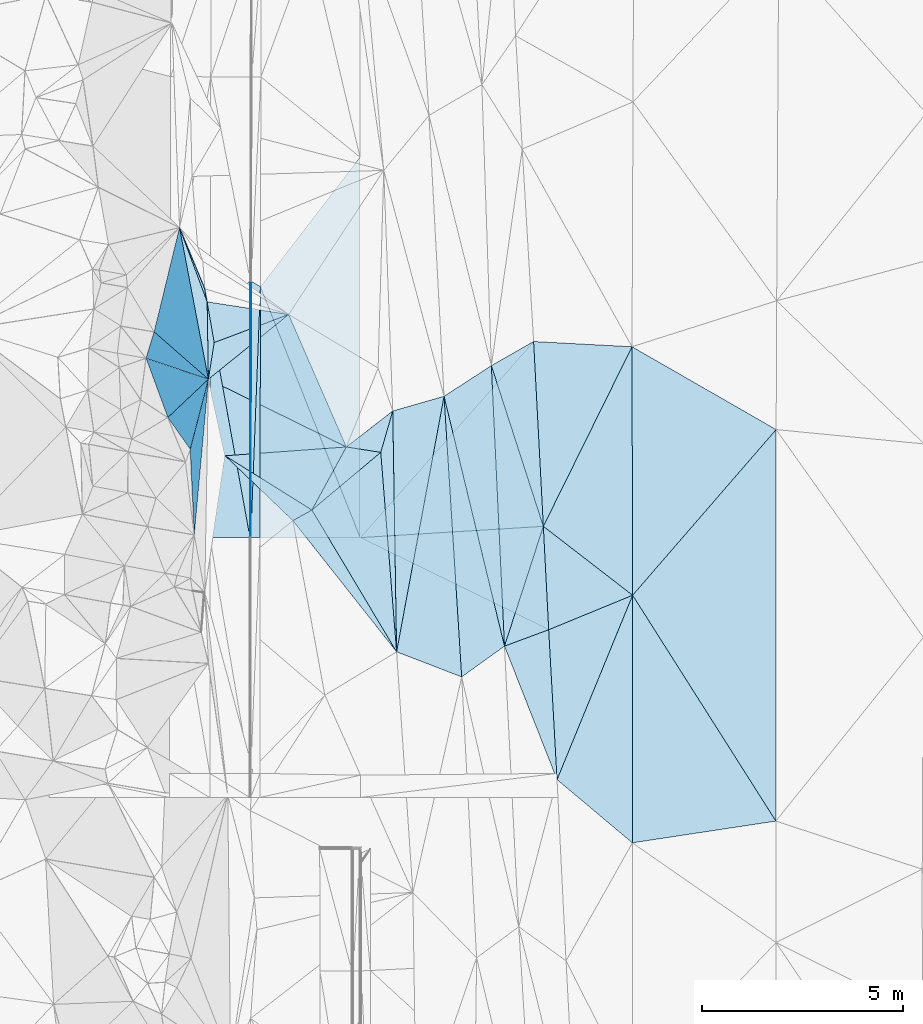
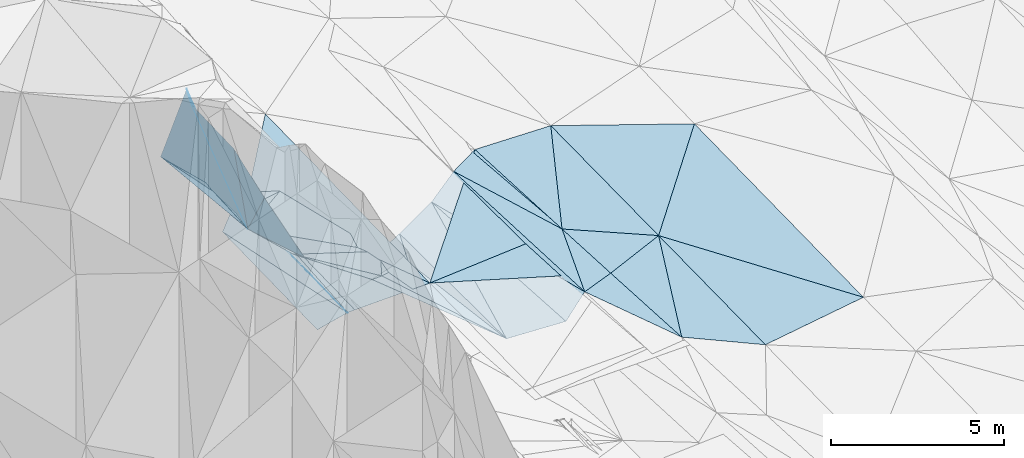
# One storey, part 89 of 275: 45 plates.
"""IFC2X3 building model written with IfcOpenShell, lengths in millimetres."""

from ifc_helpers import new_model, si_unit, frame, origin_with_axes, place, context, subcontext, project, spatial, polyline, outline, extrude, material, type_object, element, save


model = new_model("IFC2X3")

# Units and contexts
model_context = context("Model", 3, precision=1e-05, world=origin_with_axes())
body_context = subcontext(model_context, "Body", "Model", "MODEL_VIEW")
ifc_project = project(units=[si_unit("LENGTHUNIT", "METRE", prefix="MILLI"), si_unit("AREAUNIT", "SQUARE_METRE"), si_unit("VOLUMEUNIT", "CUBIC_METRE"), si_unit("MASSUNIT", "GRAM", prefix="KILO"), si_unit("TIMEUNIT", "SECOND"), si_unit("PLANEANGLEUNIT", "RADIAN"), si_unit("SOLIDANGLEUNIT", "STERADIAN"), si_unit("THERMODYNAMICTEMPERATUREUNIT", "DEGREE_CELSIUS"), si_unit("LUMINOUSINTENSITYUNIT", "LUMEN")], contexts=[model_context])

# Site, building, storey
site_placement = place(None, origin_with_axes())
site = spatial("IfcSite", under=ifc_project, at=site_placement, CompositionType="ELEMENT")
building_placement = place(site_placement, origin_with_axes())
building = spatial("IfcBuilding", under=site, at=building_placement, Name="Undefined", CompositionType="ELEMENT")
storey_placement = place(building_placement, origin_with_axes())
storey = spatial("IfcBuildingStorey", under=building, at=storey_placement, Name="Undefined", CompositionType="ELEMENT", Elevation=0.0)

# Plates
ifc_material = material()
plate_type_1 = type_object("IfcPlateType", PredefinedType="NOTDEFINED")
plate_1_placement = place(storey_placement, frame((-96883.7996210182, 94915.8950093712, 42813.0537546332), z_axis=(0.0502459376288875, 0.0222813070516805, -0.998488301938417), x_axis=(0.857254930137281, -0.513917260983165, 0.0316707060054871)))
element("IfcPlate", 1, at=plate_1_placement, inside=storey, type_object=plate_type_1, material=ifc_material, Name="00_PR", context=body_context, shape_type="SweptSolid", body=[
    extrude(outline(polyline([(0.0, 0.0), (23.3022899627686, 1.67347025126219e-10), (3277.58178710938, 5501.44140625), (0.0, 0.0)])), frame((-8.85201319254618e-08, 2.18876761149539e-07, -0.5000001331573), z_axis=(0.0, 0.0, 1.0), x_axis=(1.0, 0.0, 0.0)), (0.0, 0.0, 1.0), 1.0),
])
plate_2_placement = place(storey_placement, frame((-96863.823764153, 94903.9195599559, 42813.7917470649), z_axis=(0.0499448589059185, 0.022283031205327, -0.998503368842174), x_axis=(-0.00146779893247274, -0.999748364158116, -0.022384233948566)))
element("IfcPlate", 2, at=plate_2_placement, inside=storey, type_object=plate_type_1, material=ifc_material, Name="00_PR", context=body_context, shape_type="SweptSolid", body=[
    extrude(outline(polyline([(0.0, 0.0), (6391.8203125, -1.23254721984267e-08), (6391.853515625, 20.0253582000732), (0.0, 0.0)])), frame((-8.85201319254618e-08, 2.18876761149539e-07, -0.5000001331573), z_axis=(0.0, 0.0, 1.0), x_axis=(1.0, 0.0, 0.0)), (0.0, 0.0, 1.0), 1.0),
])
plate_type_2 = type_object("IfcPlateType", PredefinedType="NOTDEFINED")
plate_3_placement = place(storey_placement, frame((-89242.8984460067, 82484.8215259567, 42789.5002350051), z_axis=(0.0262603371728198, 0.0175187829341471, -0.999501619276365), x_axis=(-0.0555772006600647, 0.998325577359942, 0.0160379660720577)))
element("IfcPlate", 3, at=plate_3_placement, inside=storey, type_object=plate_type_2, material=ifc_material, Name="00", context=body_context, shape_type="SweptSolid", body=[
    extrude(outline(polyline([(0.0, 0.0), (3741.12280273438, 1.12049747258425e-09), (4483.5205078125, 2136.57348632813), (0.0, 0.0)])), frame((-8.85201319254618e-08, 2.18876761149539e-07, -0.5000001331573), z_axis=(0.0, 0.0, 1.0), x_axis=(1.0, 0.0, 0.0)), (0.0, 0.0, 1.0), 1.0),
])
plate_type_3 = type_object("IfcPlateType", PredefinedType="NOTDEFINED")
plate_4_placement = place(storey_placement, frame((-89583.8489318064, 88795.8791784817, 42889.5002332215), z_axis=(0.0265193549940949, 0.016888476092627, -0.999505629391834), x_axis=(0.791501493421083, -0.611073992532343, 0.0106752781124141)))
element("IfcPlate", 4, at=plate_4_placement, inside=storey, type_object=plate_type_3, material=ifc_material, Name="00", context=body_context, shape_type="SweptSolid", body=[
    extrude(outline(polyline([(0.0, 0.0), (2810.23120117188, 3.16504156216979e-09), (1679.11450195313, 1958.7431640625), (0.0, 0.0)])), frame((-8.85201319254618e-08, 2.18876761149539e-07, -0.5000001331573), z_axis=(0.0, 0.0, 1.0), x_axis=(1.0, 0.0, 0.0)), (0.0, 0.0, 1.0), 1.0),
])
plate_type_4 = type_object("IfcPlateType", PredefinedType="NOTDEFINED")
plate_5_placement = place(storey_placement, frame((-96634.0970342402, 94766.1046263451, 42822.2697535346), z_axis=(0.0502163620652991, 0.0222823277283463, -0.998489767024146), x_axis=(-0.0382035539413165, -0.99897654863145, -0.0242145359371038)))
element("IfcPlate", 5, at=plate_5_placement, inside=storey, type_object=plate_type_4, material=ifc_material, Name="00_PR", context=body_context, shape_type="SweptSolid", body=[
    extrude(outline(polyline([(0.0, 0.0), (6258.802734375, -3.84170562028885e-08), (-128.692230224609, 235.111572265625), (0.0, 0.0)])), frame((-8.85201319254618e-08, 2.18876761149539e-07, -0.5000001331573), z_axis=(0.0, 0.0, 1.0), x_axis=(1.0, 0.0, 0.0)), (0.0, 0.0, 1.0), 1.0),
])
plate_6_placement = place(storey_placement, frame((-96873.2056711443, 88513.7077095046, 42670.7157472172), z_axis=(0.049946162670482, 0.022292983617612, -0.998503081475425), x_axis=(0.0382035539401981, 0.99897654863142, 0.0242145359401193)))
element("IfcPlate", 6, at=plate_6_placement, inside=storey, type_object=plate_type_4, material=ifc_material, Name="00_PR", context=body_context, shape_type="SweptSolid", body=[
    extrude(outline(polyline([(0.0, 0.0), (6258.802734375, -3.84170562028885e-08), (8.84989261627197, 230.116790771484), (0.0, 0.0)])), frame((-8.85201319254618e-08, 2.18876761149539e-07, -0.5000001331573), z_axis=(0.0, 0.0, 1.0), x_axis=(1.0, 0.0, 0.0)), (0.0, 0.0, 1.0), 1.0),
])
plate_type_5 = type_object("IfcPlateType", PredefinedType="NOTDEFINED")
plate_7_placement = place(storey_placement, frame((-97885.4751121999, 93996.4223501791, 42542.8029896324), z_axis=(0.242091354907038, 0.0213620262537716, -0.970018267721597), x_axis=(0.722586560182467, 0.66322341127053, 0.19494453002419)))
element("IfcPlate", 7, at=plate_7_placement, inside=storey, type_object=plate_type_5, material=ifc_material, Name="00_PR", context=body_context, shape_type="SweptSolid", body=[
    extrude(outline(polyline([(0.0, 0.0), (1386.36877441406, -1.42608769237995e-09), (-2894.43920898438, 4762.67578125), (0.0, 0.0)])), frame((-8.85201319254618e-08, 2.18876761149539e-07, -0.5000001331573), z_axis=(0.0, 0.0, 1.0), x_axis=(1.0, 0.0, 0.0)), (0.0, 0.0, 1.0), 1.0),
])
plate_type_6 = type_object("IfcPlateType", PredefinedType="NOTDEFINED")
plate_8_placement = place(storey_placement, frame((-96893.1097909191, 88513.7258360305, 42669.7300420419), z_axis=(0.242499038802853, 0.0214382132062527, -0.969914748415661), x_axis=(-0.970142040956495, 0.000909900937742941, -0.24253575499099)))
element("IfcPlate", 8, at=plate_8_placement, inside=storey, type_object=plate_type_6, material=ifc_material, Name="00_PR", context=body_context, shape_type="SweptSolid", body=[
    extrude(outline(polyline([(0.0, 0.0), (1030.77587890625, -4.90399543195963e-09), (998.508178710938, 5483.05029296875), (0.0, 0.0)])), frame((-8.85201319254618e-08, 2.18876761149539e-07, -0.5000001331573), z_axis=(0.0, 0.0, 1.0), x_axis=(1.0, 0.0, 0.0)), (0.0, 0.0, 1.0), 1.0),
])
plate_type_7 = type_object("IfcPlateType", PredefinedType="NOTDEFINED")
plate_9_placement = place(storey_placement, frame((-95824.7111418685, 88938.6887629673, 43209.5378200044), z_axis=(-0.381299014340525, -0.0161019556219688, -0.924311521451557), x_axis=(0.819479834368677, 0.45686777928274, -0.346012475665752)))
element("IfcPlate", 9, at=plate_9_placement, inside=storey, type_object=plate_type_7, material=ifc_material, Name="00", context=body_context, shape_type="SweptSolid", body=[
    extrude(outline(polyline([(0.0, 0.0), (578.013854980469, -1.33877620100975e-09), (972.537292480469, 4176.74853515625), (0.0, 0.0)])), frame((-8.85201319254618e-08, 2.18876761149539e-07, -0.5000001331573), z_axis=(0.0, 0.0, 1.0), x_axis=(1.0, 0.0, 0.0)), (0.0, 0.0, 1.0), 1.0),
])
plate_type_8 = type_object("IfcPlateType", PredefinedType="NOTDEFINED")
plate_10_placement = place(storey_placement, frame((-90879.4283341748, 92799.9131308382, 42942.5060354438), z_axis=(0.15326975962527, 0.0234274685941025, -0.98790664260328), x_axis=(0.0467449375470934, -0.998771681990931, -0.0164328350178929)))
element("IfcPlate", 10, at=plate_10_placement, inside=storey, type_object=plate_type_8, material=ifc_material, Name="00", context=body_context, shape_type="SweptSolid", body=[
    extrude(outline(polyline([(0.0, 0.0), (6998.18408203125, 3.08791641145945e-08), (711.129333496094, 1227.904296875), (0.0, 0.0)])), frame((-8.85201319254618e-08, 2.18876761149539e-07, -0.5000001331573), z_axis=(0.0, 0.0, 1.0), x_axis=(1.0, 0.0, 0.0)), (0.0, 0.0, 1.0), 1.0),
])
plate_type_9 = type_object("IfcPlateType", PredefinedType="NOTDEFINED")
plate_11_placement = place(storey_placement, frame((-93240.3230114948, 85668.2743754373, 42200.5266373353), z_axis=(0.321442398579895, 0.0207548143038032, -0.946701654207079), x_axis=(-0.0159821085342203, 0.999736275545863, 0.0164909540199359)))
element("IfcPlate", 11, at=plate_11_placement, inside=storey, type_object=plate_type_9, material=ifc_material, Name="00", context=body_context, shape_type="SweptSolid", body=[
    extrude(outline(polyline([(0.0, 0.0), (6003.29150390625, 4.26516635343432e-08), (6356.11865234375, 1355.90930175781), (0.0, 0.0)])), frame((-8.85201319254618e-08, 2.18876761149539e-07, -0.5000001331573), z_axis=(0.0, 0.0, 1.0), x_axis=(1.0, 0.0, 0.0)), (0.0, 0.0, 1.0), 1.0),
])
plate_type_10 = type_object("IfcPlateType", PredefinedType="NOTDEFINED")
plate_12_placement = place(storey_placement, frame((-89826.6131757066, 93400.9616470217, 42980.157307725), z_axis=(0.0281098061484974, 0.0211559739411414, -0.999380940164908), x_axis=(0.0526335430969254, -0.998420444011483, -0.0196552059510014)))
element("IfcPlate", 12, at=plate_12_placement, inside=storey, type_object=plate_type_10, material=ifc_material, Name="00_PR", context=body_context, shape_type="SweptSolid", body=[
    extrude(outline(polyline([(0.0, 0.0), (4612.36572265625, -8.61473381519318e-09), (4655.6875, 4574.552734375), (0.0, 0.0)])), frame((-8.85201319254618e-08, 2.18876761149539e-07, -0.5000001331573), z_axis=(0.0, 0.0, 1.0), x_axis=(1.0, 0.0, 0.0)), (0.0, 0.0, 1.0), 1.0),
])
plate_type_11 = type_object("IfcPlateType", PredefinedType="NOTDEFINED")
plate_13_placement = place(storey_placement, frame((-89583.8479007317, 88795.8793626477, 42889.5002742508), z_axis=(0.0283495959587566, 0.0172982801859912, -0.999448382815032), x_axis=(0.051562720076736, -0.998544446704583, -0.0158200459457622)))
element("IfcPlate", 13, at=plate_13_placement, inside=storey, type_object=plate_type_11, material=ifc_material, Name="00_PR", context=body_context, shape_type="SweptSolid", body=[
    extrude(outline(polyline([(0.0, 0.0), (2579.95458984375, 9.15315467864275e-09), (47.7288284301758, 4574.5087890625), (0.0, 0.0)])), frame((-8.85201319254618e-08, 2.18876761149539e-07, -0.5000001331573), z_axis=(0.0, 0.0, 1.0), x_axis=(1.0, 0.0, 0.0)), (0.0, 0.0, 1.0), 1.0),
])
plate_type_12 = type_object("IfcPlateType", PredefinedType="NOTDEFINED")
plate_14_placement = place(storey_placement, frame((-96634.1081179667, 94766.1044273626, 42822.269315165), z_axis=(0.0280599211011316, 0.0218855823084741, -0.999366630478934), x_axis=(0.609228406896896, 0.792245900998046, 0.0344554869602131)))
element("IfcPlate", 14, at=plate_14_placement, inside=storey, type_object=plate_type_12, material=ifc_material, Name="00_PR", context=body_context, shape_type="SweptSolid", body=[
    extrude(outline(polyline([(0.0, 0.0), (4075.80932617188, -1.4319084584713e-08), (-3440.46997070313, 5781.93212890625), (0.0, 0.0)])), frame((-8.85201319254618e-08, 2.18876761149539e-07, -0.5000001331573), z_axis=(0.0, 0.0, 1.0), x_axis=(1.0, 0.0, 0.0)), (0.0, 0.0, 1.0), 1.0),
])
plate_type_13 = type_object("IfcPlateType", PredefinedType="NOTDEFINED")
plate_15_placement = place(storey_placement, frame((-94147.9689994148, 88514.5301511576, 42755.1683370954), z_axis=(0.0292077099668101, 0.0223415765270937, -0.999323653095822), x_axis=(-0.999572792790855, -0.000415817089473514, -0.0292242879885832)))
element("IfcPlate", 15, at=plate_15_placement, inside=storey, type_object=plate_type_13, material=ifc_material, Name="00_PR", context=body_context, shape_type="SweptSolid", body=[
    extrude(outline(polyline([(0.0, 0.0), (2496.31396484375, 2.15368345379829e-09), (2480.51586914063, 6254.16748046875), (0.0, 0.0)])), frame((-8.85201319254618e-08, 2.18876761149539e-07, -0.5000001331573), z_axis=(0.0, 0.0, 1.0), x_axis=(1.0, 0.0, 0.0)), (0.0, 0.0, 1.0), 1.0),
])
plate_type_14 = type_object("IfcPlateType", PredefinedType="NOTDEFINED")
plate_16_placement = place(storey_placement, frame((-97961.3870590126, 94390.3153888162, 43749.5185823204), z_axis=(-0.216636126647805, 0.161588182205693, -0.962786605641404), x_axis=(0.959054931487294, -0.1490691804558, -0.240815318923313)))
element("IfcPlate", 16, at=plate_16_placement, inside=storey, type_object=plate_type_14, material=ifc_material, Name="00", context=body_context, shape_type="SweptSolid", body=[
    extrude(outline(polyline([(0.0, 0.0), (2117.80541992188, 2.03726813197136e-10), (370.477844238281, 984.553771972656), (0.0, 0.0)])), frame((-8.85201319254618e-08, 2.18876761149539e-07, -0.5000001331573), z_axis=(0.0, 0.0, 1.0), x_axis=(1.0, 0.0, 0.0)), (0.0, 0.0, 1.0), 1.0),
])
plate_type_15 = type_object("IfcPlateType", PredefinedType="NOTDEFINED")
plate_17_placement = place(storey_placement, frame((-90552.3695005858, 85810.3219334699, 42827.5000925663), z_axis=(0.0116181634912458, 0.0169933164702296, -0.999788100285472), x_axis=(-0.0467449376883396, 0.998771681983659, 0.0164328350580583)))
element("IfcPlate", 17, at=plate_17_placement, inside=storey, type_object=plate_type_15, material=ifc_material, Name="00", context=body_context, shape_type="SweptSolid", body=[
    extrude(outline(polyline([(0.0, 0.0), (6998.18408203125, 3.08791641145945e-08), (2937.6357421875, 1107.11779785156), (0.0, 0.0)])), frame((-8.85201319254618e-08, 2.18876761149539e-07, -0.5000001331573), z_axis=(0.0, 0.0, 1.0), x_axis=(1.0, 0.0, 0.0)), (0.0, 0.0, 1.0), 1.0),
])
plate_type_16 = type_object("IfcPlateType", PredefinedType="NOTDEFINED")
plate_18_placement = place(storey_placement, frame((-99282.1264984289, 93642.6457282903, 48279.8318919824), z_axis=(-0.88501297984296, 0.322080138596141, -0.336179133545459), x_axis=(0.269182384228503, -0.235160677948135, -0.933938059813408)))
element("IfcPlate", 18, at=plate_18_placement, inside=storey, type_object=plate_type_16, material=ifc_material, Name="00", context=body_context, shape_type="SweptSolid", body=[
    extrude(outline(polyline([(0.0, 0.0), (5022.81689453125, -1.65382516570389e-08), (193.833465576172, 667.329467773438), (0.0, 0.0)])), frame((-8.85201319254618e-08, 2.18876761149539e-07, -0.5000001331573), z_axis=(0.0, 0.0, 1.0), x_axis=(1.0, 0.0, 0.0)), (0.0, 0.0, 1.0), 1.0),
])
plate_type_17 = type_object("IfcPlateType", PredefinedType="NOTDEFINED")
plate_19_placement = place(storey_placement, frame((-97961.4153519454, 94390.2723835429, 43749.52048035), z_axis=(-0.273129755169094, 0.0755633656719757, -0.959004856405636), x_axis=(0.0163483845132065, -0.996401591291588, -0.0831660940251505)))
element("IfcPlate", 19, at=plate_19_placement, inside=storey, type_object=plate_type_17, material=ifc_material, Name="00", context=body_context, shape_type="SweptSolid", body=[
    extrude(outline(polyline([(0.0, 0.0), (1935.88500976563, 1.16997398436069e-08), (-1884.75805664063, 683.809936523438), (0.0, 0.0)])), frame((-8.85201319254618e-08, 2.18876761149539e-07, -0.5000001331573), z_axis=(0.0, 0.0, 1.0), x_axis=(1.0, 0.0, 0.0)), (0.0, 0.0, 1.0), 1.0),
])
plate_type_18 = type_object("IfcPlateType", PredefinedType="NOTDEFINED")
plate_20_placement = place(storey_placement, frame((-97929.9390039583, 92461.3433021699, 43588.6077475897), z_axis=(-0.617710127973004, 0.0553407376891671, -0.784456245147933), x_axis=(-0.0163483846404011, 0.996401591287131, 0.0831660940535451)))
element("IfcPlate", 20, at=plate_20_placement, inside=storey, type_object=plate_type_18, material=ifc_material, Name="00", context=body_context, shape_type="SweptSolid", body=[
    extrude(outline(polyline([(0.0, 0.0), (1935.88500976563, 1.16997398436069e-08), (903.509704589844, 201.992980957031), (0.0, 0.0)])), frame((-8.85201319254618e-08, 2.18876761149539e-07, -0.5000001331573), z_axis=(0.0, 0.0, 1.0), x_axis=(1.0, 0.0, 0.0)), (0.0, 0.0, 1.0), 1.0),
])
plate_type_19 = type_object("IfcPlateType", PredefinedType="NOTDEFINED")
plate_21_placement = place(storey_placement, frame((-97512.0784328217, 90554.3436968977, 43709.5333592172), z_axis=(-0.350800398098275, -0.077563473717996, -0.933232547781575), x_axis=(0.817560860170204, -0.511335504349536, -0.264821150796838)))
element("IfcPlate", 21, at=plate_21_placement, inside=storey, type_object=plate_type_19, material=ifc_material, Name="00", context=body_context, shape_type="SweptSolid", body=[
    extrude(outline(polyline([(0.0, 0.0), (2643.29345703125, -6.188201950863e-09), (2338.10595703125, 490.877380371094), (0.0, 0.0)])), frame((-8.85201319254618e-08, 2.18876761149539e-07, -0.5000001331573), z_axis=(0.0, 0.0, 1.0), x_axis=(1.0, 0.0, 0.0)), (0.0, 0.0, 1.0), 1.0),
])
plate_type_20 = type_object("IfcPlateType", PredefinedType="NOTDEFINED")
plate_22_placement = place(storey_placement, frame((-89450.8257517819, 86219.679487049, 42849.5001014586), z_axis=(0.0139313139015157, 0.0162425769174761, -0.999771022378653), x_axis=(-0.937201727900933, -0.348285178694951, -0.0187177862187657)))
element("IfcPlate", 22, at=plate_22_placement, inside=storey, type_object=plate_type_20, material=ifc_material, Name="00", context=body_context, shape_type="SweptSolid", body=[
    extrude(outline(polyline([(0.0, 0.0), (1175.35266113281, 6.82484824210405e-09), (-773.325317382813, 2461.31420898438), (0.0, 0.0)])), frame((-8.85201319254618e-08, 2.18876761149539e-07, -0.5000001331573), z_axis=(0.0, 0.0, 1.0), x_axis=(1.0, 0.0, 0.0)), (0.0, 0.0, 1.0), 1.0),
])
plate_type_21 = type_object("IfcPlateType", PredefinedType="NOTDEFINED")
plate_23_placement = place(storey_placement, frame((-93336.6772495012, 91670.1513566405, 42299.6047653288), z_axis=(-0.49661615944151, 0.358614934340912, -0.790422494017742), x_axis=(-0.269316244468449, -0.929375304523358, -0.25244861617273)))
element("IfcPlate", 23, at=plate_23_placement, inside=storey, type_object=plate_type_21, material=ifc_material, Name="00", context=body_context, shape_type="SweptSolid", body=[
    extrude(outline(polyline([(0.0, 0.0), (1109.13659667969, 6.09725248068571e-09), (1063.4794921875, 1054.37915039063), (0.0, 0.0)])), frame((-8.85201319254618e-08, 2.18876761149539e-07, -0.5000001331573), z_axis=(0.0, 0.0, 1.0), x_axis=(1.0, 0.0, 0.0)), (0.0, 0.0, 1.0), 1.0),
])
plate_type_22 = type_object("IfcPlateType", PredefinedType="NOTDEFINED")
plate_24_placement = place(storey_placement, frame((-95351.129565559, 89202.8233987656, 43009.588678527), z_axis=(-0.559519852954974, 0.101369413941813, -0.82259453928794), x_axis=(0.468318553325536, 0.857533685964041, -0.212870171813721)))
element("IfcPlate", 24, at=plate_24_placement, inside=storey, type_object=plate_type_22, material=ifc_material, Name="00", context=body_context, shape_type="SweptSolid", body=[
    extrude(outline(polyline([(0.0, 0.0), (1832.10266113281, 5.64614310860634e-09), (2245.99853515625, 970.819274902344), (0.0, 0.0)])), frame((-8.85201319254618e-08, 2.18876761149539e-07, -0.5000001331573), z_axis=(0.0, 0.0, 1.0), x_axis=(1.0, 0.0, 0.0)), (0.0, 0.0, 1.0), 1.0),
])
plate_type_23 = type_object("IfcPlateType", PredefinedType="NOTDEFINED")
plate_25_placement = place(storey_placement, frame((-87374.8020338737, 93271.2593343883, 43039.5002835939), z_axis=(0.0284851870048266, 0.0194364996168503, -0.999405231427145), x_axis=(0.00246315862177639, -0.999809269351235, -0.0193741520834898)))
element("IfcPlate", 25, at=plate_25_placement, inside=storey, type_object=plate_type_23, material=ifc_material, Name="00", context=body_context, shape_type="SweptSolid", body=[
    extrude(outline(polyline([(0.0, 0.0), (6193.8193359375, -3.46335582435131e-08), (4471.990234375, 2220.96899414063), (0.0, 0.0)])), frame((-8.85201319254618e-08, 2.18876761149539e-07, -0.5000001331573), z_axis=(0.0, 0.0, 1.0), x_axis=(1.0, 0.0, 0.0)), (0.0, 0.0, 1.0), 1.0),
])
plate_type_24 = type_object("IfcPlateType", PredefinedType="NOTDEFINED")
plate_26_placement = place(storey_placement, frame((-99483.4677256671, 92984.8462766405, 48179.8512779859), z_axis=(-0.938362617515616, -0.176139115216893, -0.297406472928637), x_axis=(0.318647814185505, -0.107411710949969, -0.941767643777169)))
element("IfcPlate", 26, at=plate_26_placement, inside=storey, type_object=plate_type_24, material=ifc_material, Name="00", context=body_context, shape_type="SweptSolid", body=[
    extrude(outline(polyline([(0.0, 0.0), (4874.87548828125, 2.38651409745216e-09), (1122.80407714844, 1385.57250976563), (0.0, 0.0)])), frame((-8.85201319254618e-08, 2.18876761149539e-07, -0.5000001331573), z_axis=(0.0, 0.0, 1.0), x_axis=(1.0, 0.0, 0.0)), (0.0, 0.0, 1.0), 1.0),
])
plate_type_25 = type_object("IfcPlateType", PredefinedType="NOTDEFINED")
plate_27_placement = place(storey_placement, frame((-89583.8505598562, 88795.8811099937, 42889.5002303665), z_axis=(0.0232729874879748, 0.020761003880783, -0.999513556071776), x_axis=(-0.307843431550687, 0.951353690471757, 0.0125927469944621)))
element("IfcPlate", 27, at=plate_27_placement, inside=storey, type_object=plate_type_25, material=ifc_material, Name="00", context=body_context, shape_type="SweptSolid", body=[
    extrude(outline(polyline([(0.0, 0.0), (4208.77197265625, -3.45025910064578e-08), (4456.92724609375, 1187.26574707031), (0.0, 0.0)])), frame((-8.85201319254618e-08, 2.18876761149539e-07, -0.5000001331573), z_axis=(0.0, 0.0, 1.0), x_axis=(1.0, 0.0, 0.0)), (0.0, 0.0, 1.0), 1.0),
])
plate_type_26 = type_object("IfcPlateType", PredefinedType="NOTDEFINED")
plate_28_placement = place(storey_placement, frame((-90552.2908307784, 85810.3270607842, 42827.5073634699), z_axis=(0.168934597926275, 0.0272532928084111, -0.985250404544239), x_axis=(-0.802293724827856, -0.576850243557552, -0.153520603208291)))
element("IfcPlate", 28, at=plate_28_placement, inside=storey, type_object=plate_type_26, material=ifc_material, Name="00", context=body_context, shape_type="SweptSolid", body=[
    extrude(outline(polyline([(0.0, 0.0), (1328.81188964844, 3.87080945074558e-09), (-2369.9111328125, 5951.32958984375), (0.0, 0.0)])), frame((-8.85201319254618e-08, 2.18876761149539e-07, -0.5000001331573), z_axis=(0.0, 0.0, 1.0), x_axis=(1.0, 0.0, 0.0)), (0.0, 0.0, 1.0), 1.0),
])
plate_type_27 = type_object("IfcPlateType", PredefinedType="NOTDEFINED")
plate_29_placement = place(storey_placement, frame((-93336.1087340686, 91669.9835023045, 42299.6161773737), z_axis=(0.640505781841877, 0.0229013234298685, -0.767611798249797), x_axis=(0.015982108570847, -0.999736275545812, -0.0164909539874937)))
element("IfcPlate", 29, at=plate_29_placement, inside=storey, type_object=plate_type_27, material=ifc_material, Name="00", context=body_context, shape_type="SweptSolid", body=[
    extrude(outline(polyline([(0.0, 0.0), (6003.29150390625, 4.26516635343432e-08), (1030.37585449219, 410.499359130859), (0.0, 0.0)])), frame((-8.85201319254618e-08, 2.18876761149539e-07, -0.5000001331573), z_axis=(0.0, 0.0, 1.0), x_axis=(1.0, 0.0, 0.0)), (0.0, 0.0, 1.0), 1.0),
])
plate_type_28 = type_object("IfcPlateType", PredefinedType="NOTDEFINED")
plate_30_placement = place(storey_placement, frame((-98281.8339065427, 88585.1137838118, 45059.9122951844), z_axis=(-0.984239486557923, 0.0227536832086476, -0.175370758681816), x_axis=(-0.0437806682689025, 0.929463852477918, 0.366306156135595)))
element("IfcPlate", 30, at=plate_30_placement, inside=storey, type_object=plate_type_28, material=ifc_material, Name="00", context=body_context, shape_type="SweptSolid", body=[
    extrude(outline(polyline([(0.0, 0.0), (2293.16381835938, -9.28048393689096e-09), (3048.5654296875, 2831.751953125), (0.0, 0.0)])), frame((-8.85201319254618e-08, 2.18876761149539e-07, -0.5000001331573), z_axis=(0.0, 0.0, 1.0), x_axis=(1.0, 0.0, 0.0)), (0.0, 0.0, 1.0), 1.0),
])
plate_type_29 = type_object("IfcPlateType", PredefinedType="NOTDEFINED")
plate_31_placement = place(storey_placement, frame((-98649.4648640243, 96242.1418787619, 44091.6848108484), z_axis=(0.682399841879062, 0.370154762374519, -0.630329999044068), x_axis=(0.379534490447098, -0.916384665343485, -0.127250601901802)))
element("IfcPlate", 31, at=plate_31_placement, inside=storey, type_object=plate_type_29, material=ifc_material, Name="00", context=body_context, shape_type="SweptSolid", body=[
    extrude(outline(polyline([(0.0, 0.0), (1666.00390625, -8.46921466290951e-09), (2001.72937011719, 113.966598510742), (0.0, 0.0)])), frame((-8.85201319254618e-08, 2.18876761149539e-07, -0.5000001331573), z_axis=(0.0, 0.0, 1.0), x_axis=(1.0, 0.0, 0.0)), (0.0, 0.0, 1.0), 1.0),
])
plate_type_30 = type_object("IfcPlateType", PredefinedType="NOTDEFINED")
plate_32_placement = place(storey_placement, frame((-98940.1131926599, 91508.4971687505, 47339.8548429227), z_axis=(-0.946772941702743, -0.139145734221923, -0.29027480343181), x_axis=(0.252519381145938, 0.238203217995153, -0.937812981933192)))
element("IfcPlate", 32, at=plate_32_placement, inside=storey, type_object=plate_type_30, material=ifc_material, Name="00", context=body_context, shape_type="SweptSolid", body=[
    extrude(outline(polyline([(0.0, 0.0), (3999.7314453125, -1.58179318532348e-08), (1302.66247558594, 1146.85241699219), (0.0, 0.0)])), frame((-8.85201319254618e-08, 2.18876761149539e-07, -0.5000001331573), z_axis=(0.0, 0.0, 1.0), x_axis=(1.0, 0.0, 0.0)), (0.0, 0.0, 1.0), 1.0),
])
plate_type_31 = type_object("IfcPlateType", PredefinedType="NOTDEFINED")
plate_33_placement = place(storey_placement, frame((-97929.7942442535, 92461.2500082911, 43588.5322514966), z_axis=(-0.328192125594288, -0.131249483906155, -0.935448289149256), x_axis=(0.870199215407588, -0.427265360509355, -0.245352067879669)))
element("IfcPlate", 33, at=plate_33_placement, inside=storey, type_object=plate_type_31, material=ifc_material, Name="00", context=body_context, shape_type="SweptSolid", body=[
    extrude(outline(polyline([(0.0, 0.0), (3949.4267578125, 8.25821189209819e-09), (1148.58471679688, 1583.12487792969), (0.0, 0.0)])), frame((-8.85201319254618e-08, 2.18876761149539e-07, -0.5000001331573), z_axis=(0.0, 0.0, 1.0), x_axis=(1.0, 0.0, 0.0)), (0.0, 0.0, 1.0), 1.0),
])
plate_type_32 = type_object("IfcPlateType", PredefinedType="NOTDEFINED")
plate_34_placement = place(storey_placement, frame((-98650.2857063534, 96241.8812874375, 44091.8807416745), z_axis=(-0.959334596781962, -0.15101554071693, -0.238477332002781), x_axis=(0.1855475911811, -0.974052103639068, -0.129593945858583)))
element("IfcPlate", 34, at=plate_34_placement, inside=storey, type_object=plate_type_32, material=ifc_material, Name="00", context=body_context, shape_type="SweptSolid", body=[
    extrude(outline(polyline([(0.0, 0.0), (3881.35424804688, -4.35102265328169e-09), (1872.03845214844, 4603.4052734375), (0.0, 0.0)])), frame((-8.85201319254618e-08, 2.18876761149539e-07, -0.5000001331573), z_axis=(0.0, 0.0, 1.0), x_axis=(1.0, 0.0, 0.0)), (0.0, 0.0, 1.0), 1.0),
])
plate_type_33 = type_object("IfcPlateType", PredefinedType="NOTDEFINED")
plate_35_placement = place(storey_placement, frame((-94492.959076023, 90773.9025171311, 42619.5154932614), z_axis=(-0.233828236495592, 0.0801857638280623, -0.968965736802222), x_axis=(-0.870199215409394, 0.427265360505973, 0.245352067879151)))
element("IfcPlate", 35, at=plate_35_placement, inside=storey, type_object=plate_type_33, material=ifc_material, Name="00", context=body_context, shape_type="SweptSolid", body=[
    extrude(outline(polyline([(0.0, 0.0), (3949.4267578125, 8.25821189209819e-09), (2813.15771484375, 2330.4384765625), (0.0, 0.0)])), frame((-8.85201319254618e-08, 2.18876761149539e-07, -0.5000001331573), z_axis=(0.0, 0.0, 1.0), x_axis=(1.0, 0.0, 0.0)), (0.0, 0.0, 1.0), 1.0),
])
plate_type_34 = type_object("IfcPlateType", PredefinedType="NOTDEFINED")
plate_36_placement = place(storey_placement, frame((-97512.0710030074, 90554.3574708341, 43709.5296985024), z_axis=(-0.335941232436547, -0.0500136780861188, -0.940554155991728), x_axis=(0.938384261942742, 0.0682187395743315, -0.338793713798036)))
element("IfcPlate", 36, at=plate_36_placement, inside=storey, type_object=plate_type_34, material=ifc_material, Name="00", context=body_context, shape_type="SweptSolid", body=[
    extrude(outline(polyline([(0.0, 0.0), (3217.29711914063, -7.87258613854647e-09), (2172.84887695313, 1505.23352050781), (0.0, 0.0)])), frame((-8.85201319254618e-08, 2.18876761149539e-07, -0.5000001331573), z_axis=(0.0, 0.0, 1.0), x_axis=(1.0, 0.0, 0.0)), (0.0, 0.0, 1.0), 1.0),
])
plate_type_35 = type_object("IfcPlateType", PredefinedType="NOTDEFINED")
plate_37_placement = place(storey_placement, frame((-93635.3649464702, 90639.1336577479, 42019.5560484664), z_axis=(-0.455001907041352, -0.068452354407343, -0.887855584971354), x_axis=(0.0790916326385322, -0.996207170305503, 0.0362737850034265)))
element("IfcPlate", 37, at=plate_37_placement, inside=storey, type_object=plate_type_35, material=ifc_material, Name="00", context=body_context, shape_type="SweptSolid", body=[
    extrude(outline(polyline([(0.0, 0.0), (4989.82958984375, -4.94765117764473e-09), (1331.15966796875, 2053.0498046875), (0.0, 0.0)])), frame((-8.85201319254618e-08, 2.18876761149539e-07, -0.5000001331573), z_axis=(0.0, 0.0, 1.0), x_axis=(1.0, 0.0, 0.0)), (0.0, 0.0, 1.0), 1.0),
])
plate_type_36 = type_object("IfcPlateType", PredefinedType="NOTDEFINED")
plate_38_placement = place(storey_placement, frame((-95930.2612959103, 94074.5202750156, 43239.5057532627), z_axis=(-0.148659237711875, -0.0295879555792055, -0.988445741519264), x_axis=(-0.77118427661837, -0.622217962494452, 0.134609132847123)))
element("IfcPlate", 38, at=plate_38_placement, inside=storey, type_object=plate_type_36, material=ifc_material, Name="00", context=body_context, shape_type="SweptSolid", body=[
    extrude(outline(polyline([(0.0, 0.0), (2592.69189453125, 3.55066731572151e-09), (1906.78662109375, 621.823913574219), (0.0, 0.0)])), frame((-8.85201319254618e-08, 2.18876761149539e-07, -0.5000001331573), z_axis=(0.0, 0.0, 1.0), x_axis=(1.0, 0.0, 0.0)), (0.0, 0.0, 1.0), 1.0),
])
plate_type_37 = type_object("IfcPlateType", PredefinedType="NOTDEFINED")
plate_39_placement = place(storey_placement, frame((-91618.3407095447, 85043.8044237094, 42623.5180082702), z_axis=(0.264043520875663, 0.0328764022100132, -0.963950289828946), x_axis=(-0.906757362086234, 0.349102579497242, -0.236470876199978)))
element("IfcPlate", 39, at=plate_39_placement, inside=storey, type_object=plate_type_37, material=ifc_material, Name="00", context=body_context, shape_type="SweptSolid", body=[
    extrude(outline(polyline([(0.0, 0.0), (1788.80383300781, -5.32600097358227e-09), (2811.92504882813, 6418.09619140625), (0.0, 0.0)])), frame((-8.85201319254618e-08, 2.18876761149539e-07, -0.5000001331573), z_axis=(0.0, 0.0, 1.0), x_axis=(1.0, 0.0, 0.0)), (0.0, 0.0, 1.0), 1.0),
])
plate_type_38 = type_object("IfcPlateType", PredefinedType="NOTDEFINED")
plate_40_placement = place(storey_placement, frame((-89242.9047237891, 82484.8211727513, 42789.5001046341), z_axis=(0.0137148903618088, 0.0168245934360268, -0.999764389662923), x_axis=(-0.36636284350854, 0.930411325419321, 0.0106316709786778)))
element("IfcPlate", 40, at=plate_40_placement, inside=storey, type_object=plate_type_38, material=ifc_material, Name="00", context=body_context, shape_type="SweptSolid", body=[
    extrude(outline(polyline([(0.0, 0.0), (3574.22631835938, -1.72440195456147e-08), (3551.76733398438, 1175.13806152344), (0.0, 0.0)])), frame((-8.85201319254618e-08, 2.18876761149539e-07, -0.5000001331573), z_axis=(0.0, 0.0, 1.0), x_axis=(1.0, 0.0, 0.0)), (0.0, 0.0, 1.0), 1.0),
])
plate_type_39 = type_object("IfcPlateType", PredefinedType="NOTDEFINED")
plate_41_placement = place(storey_placement, frame((-87359.5451497031, 87078.619548884, 42919.5002710452), z_axis=(0.0295420147031124, 0.0161714200705442, -0.99943271636473), x_axis=(-0.000975682317494133, -0.999868176948399, -0.0162073060654735)))
element("IfcPlate", 41, at=plate_41_placement, inside=storey, type_object=plate_type_39, material=ifc_material, Name="00", context=body_context, shape_type="SweptSolid", body=[
    extrude(outline(polyline([(0.0, 0.0), (6170.056640625, -2.87836883217096e-08), (4597.1376953125, 1879.68762207031), (0.0, 0.0)])), frame((-8.85201319254618e-08, 2.18876761149539e-07, -0.5000001331573), z_axis=(0.0, 0.0, 1.0), x_axis=(1.0, 0.0, 0.0)), (0.0, 0.0, 1.0), 1.0),
])
plate_type_40 = type_object("IfcPlateType", PredefinedType="NOTDEFINED")
plate_42_placement = place(storey_placement, frame((-87374.802344581, 93271.2593352808, 43039.500275703), z_axis=(0.0278681336537207, 0.0194353170865632, -0.999422651122338), x_axis=(0.866903879106903, -0.498264884333229, 0.0144834191335455)))
element("IfcPlate", 42, at=plate_42_placement, inside=storey, type_object=plate_type_40, material=ifc_material, Name="00", context=body_context, shape_type="SweptSolid", body=[
    extrude(outline(polyline([(0.0, 0.0), (4142.66845703125, 2.35086190514266e-08), (3097.06201171875, 5363.9169921875), (0.0, 0.0)])), frame((-8.85201319254618e-08, 2.18876761149539e-07, -0.5000001331573), z_axis=(0.0, 0.0, 1.0), x_axis=(1.0, 0.0, 0.0)), (0.0, 0.0, 1.0), 1.0),
])
plate_type_41 = type_object("IfcPlateType", PredefinedType="NOTDEFINED")
plate_43_placement = place(storey_placement, frame((-83783.5071996429, 91207.1132391029, 43099.5002758865), z_axis=(0.027853444838717, 0.019448047157657, -0.999422812963748), x_axis=(-0.000610148365836438, -0.999810204966288, -0.019472590075296)))
element("IfcPlate", 43, at=plate_43_placement, inside=storey, type_object=plate_type_41, material=ifc_material, Name="00", context=body_context, shape_type="SweptSolid", body=[
    extrude(outline(polyline([(0.0, 0.0), (9757.3046875, -1.83790689334273e-08), (4133.3955078125, 3574.90454101563), (0.0, 0.0)])), frame((-8.85201319254618e-08, 2.18876761149539e-07, -0.5000001331573), z_axis=(0.0, 0.0, 1.0), x_axis=(1.0, 0.0, 0.0)), (0.0, 0.0, 1.0), 1.0),
])
plate_type_42 = type_object("IfcPlateType", PredefinedType="NOTDEFINED")
plate_44_placement = place(storey_placement, frame((-87359.5485617258, 87078.6195581691, 42919.5001801173), z_axis=(0.0227035678221377, 0.016180987553757, -0.999611286275786), x_axis=(0.535730693791366, -0.844387572089716, -0.00150060996132427)))
element("IfcPlate", 44, at=plate_44_placement, inside=storey, type_object=plate_type_42, material=ifc_material, Name="00", context=body_context, shape_type="SweptSolid", body=[
    extrude(outline(polyline([(0.0, 0.0), (6663.955078125, 3.21961124427617e-09), (5206.1572265625, 3311.42333984375), (0.0, 0.0)])), frame((-8.85201319254618e-08, 2.18876761149539e-07, -0.5000001331573), z_axis=(0.0, 0.0, 1.0), x_axis=(1.0, 0.0, 0.0)), (0.0, 0.0, 1.0), 1.0),
])
plate_type_43 = type_object("IfcPlateType", PredefinedType="NOTDEFINED")
plate_45_placement = place(storey_placement, frame((-89826.6145637478, 93400.9615276831, 42979.5002581166), z_axis=(0.0255629607531855, 0.0208805814582209, -0.999455119730495), x_axis=(0.998305664351669, -0.0528106404122965, 0.0244302431960115)))
element("IfcPlate", 45, at=plate_45_placement, inside=storey, type_object=plate_type_43, material=ifc_material, Name="00", context=body_context, shape_type="SweptSolid", body=[
    extrude(outline(polyline([(0.0, 0.0), (2455.97241210938, -2.27009877562523e-09), (483.352355957031, 4586.95654296875), (0.0, 0.0)])), frame((-8.85201319254618e-08, 2.18876761149539e-07, -0.5000001331573), z_axis=(0.0, 0.0, 1.0), x_axis=(1.0, 0.0, 0.0)), (0.0, 0.0, 1.0), 1.0),
])

save(model, "model.ifc")
